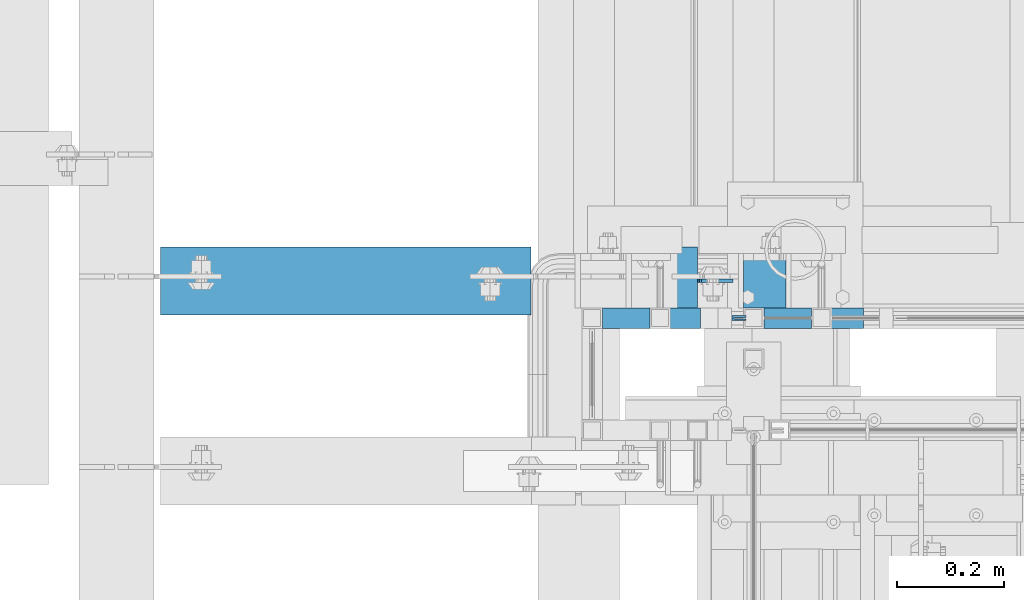
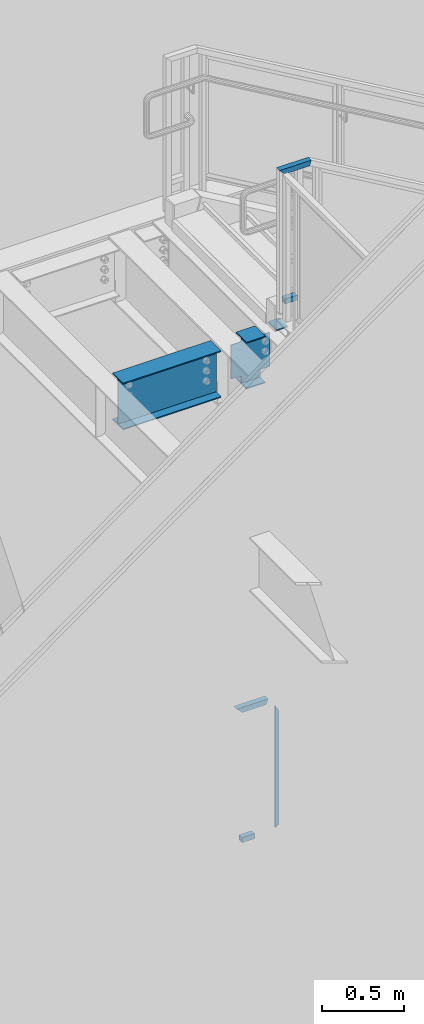
# One storey, part 929 of 1179: 4 beams, 4 members, 5 elements without a shape of their own.
"""IFC2X3 building model written with IfcOpenShell, lengths in millimetres."""

from ifc_helpers import new_model, si_unit, frame, origin_with_axes, place, context, subcontext, project, spatial, faceted_brep, material, type_object, element, aggregate, save


model = new_model("IFC2X3")

# Units and contexts
model_context = context("Model", 3, precision=1e-05, world=origin_with_axes())
body_context = subcontext(model_context, "Body", "Model", "MODEL_VIEW")
ifc_project = project(units=[si_unit("LENGTHUNIT", "METRE", prefix="MILLI"), si_unit("AREAUNIT", "SQUARE_METRE"), si_unit("VOLUMEUNIT", "CUBIC_METRE"), si_unit("MASSUNIT", "GRAM", prefix="KILO"), si_unit("TIMEUNIT", "SECOND"), si_unit("PLANEANGLEUNIT", "RADIAN"), si_unit("SOLIDANGLEUNIT", "STERADIAN"), si_unit("THERMODYNAMICTEMPERATUREUNIT", "DEGREE_CELSIUS"), si_unit("LUMINOUSINTENSITYUNIT", "LUMEN")], contexts=[model_context])

# Site, building, storey
site_placement = place(None, origin_with_axes())
site = spatial("IfcSite", under=ifc_project, at=site_placement, CompositionType="ELEMENT")
building_placement = place(site_placement, origin_with_axes())
building = spatial("IfcBuilding", under=site, at=building_placement, Name="Undefined", CompositionType="ELEMENT")
storey_placement = place(building_placement, origin_with_axes())
storey = spatial("IfcBuildingStorey", under=building, at=storey_placement, Name="Undefined", CompositionType="ELEMENT", Elevation=0.0)

# Assembly, beam
assembly_1_placement = place(storey_placement, origin_with_axes())
assembly_1 = element("IfcElementAssembly", 1, at=assembly_1_placement, inside=storey, Name="GUARDRAIL", AssemblyPlace="NOTDEFINED", PredefinedType="RIGID_FRAME")
ifc_material_1 = material(Name="STEEL/BUY-OUT")
beam_type_1 = type_object("IfcBeamType", PredefinedType="NOTDEFINED")
beam_1_placement = place(assembly_1_placement, frame((19591.0331071758, 39677.9751661867, 4786.47180551808), z_axis=(0.0, 0.0, -1.0), x_axis=(-1.0, 0.0, 0.0)))
beam_1 = element("IfcBeam", 2, at=beam_1_placement, type_object=beam_type_1, material=ifc_material_1, Name="U-EDGE", context=body_context, shape_type="Brep", body=[
    faceted_brep([(2.91038304567337e-11, 7.9375, 440.175302877862), (25.3999999999687, 7.9375, 454.819), (25.400000000016, 7.9375, -454.819), (2.91038304567337e-11, 7.9375, -410.76229705665), (2.91038304567337e-11, 4.76249999999709, 440.175302877862), (2.91038304567337e-11, 4.76249999999709, -410.76229705665), (22.2250000000131, 4.76249999999709, 452.988538277322), (22.2250000000131, 4.76249999999709, -449.311912132071), (22.2250000000131, 1.58750000000146, 452.988538277322), (22.2250000000131, 1.58750000000146, -449.311912132071), (0.0, 1.58750000000146, 440.175302877845), (0.0, 1.58750000000146, -410.7622970566), (0.0, -1.58750000000146, 440.175302877845), (0.0, -1.58750000000146, -410.7622970566), (25.3999999999687, -1.58750000000146, 454.819), (25.400000000016, -1.58750000000146, -454.819)], [[[0, 1, 2, 3]], [[4, 0, 3, 5]], [[6, 4, 5, 7]], [[8, 6, 7, 9]], [[10, 8, 9, 11]], [[12, 10, 11, 13]], [[14, 12, 13, 15]], [[11, 9, 7, 5, 3, 2, 15, 13]], [[1, 14, 15, 2]], [[0, 4, 6, 8, 10, 12, 14, 1]]]),
])

# Assembly, members
assembly_2_placement = place(storey_placement, origin_with_axes())
assembly_2 = element("IfcElementAssembly", 3, at=assembly_2_placement, inside=storey, Name="GUARDRAIL", AssemblyPlace="NOTDEFINED", PredefinedType="RIGID_FRAME")
ifc_material_2 = material()
member_type = type_object("IfcMemberType", Name="HSS1-1/2X1-1/2X1/8", PredefinedType="NOTDEFINED")
member_1_placement = place(assembly_2_placement, frame((19611.9749972912, 39681.1500007796, 8242.29999930855), z_axis=(0.0, -1.0, 0.0), x_axis=(1.0, 0.0, 0.0)))
member_1 = element("IfcMember", 4, at=member_1_placement, type_object=member_type, material=ifc_material_2, Name="BOTTOM_RAIL", ObjectType="HSS1-1/2X1-1/2X1/8", context=body_context, shape_type="Brep", body=[
    faceted_brep([(12.7000019468469, -19.0499992349996, 19.0500000000029), (12.7000017945174, 19.0499992350015, 19.0499992350015), (12.7000017945174, 19.0499992350015, -19.0499992350015), (12.7000019468469, -19.0499992349996, -19.0499992350015), (12.7000019362204, -15.874999282998, 15.874999282998), (12.7000019362204, -15.874999282998, -15.874999282998), (12.7000018092185, 15.8749992830017, -15.874999282998), (12.7000018092185, 15.8749992830017, 15.874999282998), (101.600003324515, 19.0499992350051, -19.0499992350015), (101.60000347684, -19.049999234996, -19.0499992350015), (101.60000347684, -19.049999234996, 19.0499992350015), (101.600003324515, 19.0499992350051, 19.0499992350015), (101.600003464151, -15.8749992829944, 15.874999282998), (101.600003337207, 15.8749992830053, 15.874999282998), (101.600003337207, 15.8749992830053, -15.874999282998), (101.600003464151, -15.8749992829944, -15.874999282998)], [[[0, 1, 2, 3], [4, 5, 6, 7]], [[8, 9, 3, 2]], [[9, 10, 0, 3]], [[10, 11, 1, 0]], [[11, 8, 2, 1]], [[10, 9, 8, 11], [12, 13, 14, 15]], [[13, 12, 4, 7]], [[14, 13, 7, 6]], [[15, 14, 6, 5]], [[12, 15, 5, 4]]]),
])
member_2_placement = place(assembly_2_placement, frame((19605.6249999269, 39681.1500007796, 9213.85000057691), z_axis=(0.0, 0.0, 1.0), x_axis=(1.0, 0.0, 0.0)))
member_2 = element("IfcMember", 5, at=member_2_placement, type_object=member_type, material=ifc_material_2, Name="TOP_RAIL", ObjectType="HSS1-1/2X1-1/2X1/8", context=body_context, shape_type="Brep", body=[
    faceted_brep([(15.874999282998, 15.874999282998, -15.8749992829999), (15.874999282998, -15.874999282998, -15.8749992829999), (195.733208365273, -15.874999282998, -15.8749992829999), (195.733208365273, 15.874999282998, -15.8749992829999), (-15.8749992830017, -15.874999282998, 15.8749992829999), (204.316793203543, -15.874999282998, 15.8749992829999), (-15.8749992830017, 15.874999282998, 15.8749992829999), (204.316793203543, 15.874999282998, 15.8749992829999), (19.0499999999993, 19.0499992349996, -19.0499992350015), (-19.0499992350015, 19.0499992350015, 19.0499992349996), (205.175151713163, 19.0499992350015, 19.0499992349996), (194.874849855652, 19.0499992350015, -19.0499992349996), (-19.0499992350015, -19.0499992350015, 19.0499992349996), (205.175151713163, -19.0499992350015, 19.0499992349996), (19.0499999999993, -19.0499992349996, -19.0499992350015), (194.874849855652, -19.0499992350015, -19.0499992349996)], [[[0, 1, 2, 3]], [[1, 4, 5, 2]], [[4, 6, 7, 5]], [[6, 0, 3, 7]], [[8, 9, 10, 11]], [[9, 12, 13, 10]], [[12, 14, 15, 13]], [[14, 8, 11, 15]], [[13, 15, 11, 10], [5, 7, 3, 2]], [[14, 12, 9, 8], [6, 4, 1, 0]]]),
])
aggregate(assembly_2, [member_1, member_2])

# Member
member_3_placement = place(assembly_1_placement, frame((19304.0000001842, 39681.150000778, 4330.70000016911), z_axis=(0.0, -1.0, 0.0), x_axis=(1.0, 0.0, 0.0)))
member_3 = element("IfcMember", 6, at=member_3_placement, type_object=member_type, material=ifc_material_2, Name="POST", ObjectType="HSS1-1/2X1-1/2X1/8", context=body_context, shape_type="Brep", body=[
    faceted_brep([(107.950001301364, -19.0499992349942, 19.0499992350015), (107.950001301364, -19.0499992349942, -19.0499992350015), (107.949999235003, 19.0499992349996, -19.0499992350015), (107.949999235003, 19.0499992349996, 19.0499992350015), (107.950001288671, -15.8749992829944, 15.874999282998), (107.950001161731, 15.8749992830053, 15.874999282998), (107.950001161731, 15.8749992830053, -15.874999282998), (107.950001288671, -15.8749992829944, -15.874999282998), (19.0499999999993, 19.0499992349996, -19.0499992350015), (19.0499999999993, 19.0499992349996, 19.0499992350015), (19.0499999999993, -19.0499992349996, 19.0500001223481), (19.0499999999993, -19.0499992349996, -19.0499992350015), (19.0499999999993, -15.8749992829999, 15.874999282998), (19.0499999999993, -15.8749992829999, -15.874999282998), (19.0499999999993, 15.8749992829999, -15.874999282998), (19.0499999999993, 15.8749992829999, 15.874999282998)], [[[0, 1, 2, 3], [4, 5, 6, 7]], [[3, 2, 8, 9]], [[9, 10, 0, 3]], [[10, 11, 1, 0]], [[11, 8, 2, 1]], [[10, 9, 8, 11], [12, 13, 14, 15]], [[13, 12, 4, 7]], [[14, 13, 7, 6]], [[15, 14, 6, 5]], [[12, 15, 5, 4]]]),
])

member_4_placement = place(assembly_1_placement, frame((19303.9999999845, 39681.150000778, 5302.25), z_axis=(0.0, 0.0, 1.0), x_axis=(1.0, 0.0, 0.0)))
member_4 = element("IfcMember", 7, at=member_4_placement, type_object=member_type, material=ifc_material_2, Name="TOP_RAIL", ObjectType="HSS1-1/2X1-1/2X1/8", context=body_context, shape_type="Brep", body=[
    faceted_brep([(15.874999282998, 15.874999282998, -15.8749992829999), (15.874999282998, -15.874999282998, -15.8749992829999), (192.585831865978, -15.874999282998, -15.8749992829999), (192.585831865978, 15.874999282998, -15.8749992829999), (-15.8749992830017, -15.874999282998, 15.8749992829999), (201.114170631146, -15.874999282998, 15.8749992829999), (-15.8749992830017, 15.874999282998, 15.8749992829999), (201.114170631146, 15.874999282998, 15.8749992829999), (19.0499999999993, 19.0499992349996, -19.0499992350015), (-19.0499992350015, 19.0499992350015, 19.0499992349996), (201.96700453329, 19.0499992350015, 19.0499992349996), (191.732997963838, 19.0499992350015, -19.0499992349996), (-19.0499992350015, -19.0499992350015, 19.0499992349996), (201.96700453329, -19.0499992350015, 19.0499992349996), (19.0499999999993, -19.0499992349996, -19.0499992350015), (191.732997963838, -19.0499992350015, -19.0499992349996)], [[[0, 1, 2, 3]], [[1, 4, 5, 2]], [[4, 6, 7, 5]], [[6, 0, 3, 7]], [[8, 9, 10, 11]], [[9, 12, 13, 10]], [[12, 14, 15, 13]], [[14, 8, 11, 15]], [[13, 15, 11, 10], [5, 7, 3, 2]], [[14, 12, 9, 8], [6, 4, 1, 0]]]),
])

aggregate(assembly_1, [beam_1, member_3, member_4])

# Assembly, beam
assembly_3_placement = place(storey_placement, origin_with_axes())
assembly_3 = element("IfcElementAssembly", 8, at=assembly_3_placement, inside=storey, Name="STAIR", AssemblyPlace="NOTDEFINED", PredefinedType="RIGID_FRAME")
ifc_material_3 = material(Name="STEEL/A36")
beam_type_2 = type_object("IfcBeamType", PredefinedType="NOTDEFINED")
beam_2_placement = place(assembly_3_placement, frame((19665.94999773, 39751.0000000355, 8018.46249982856), z_axis=(0.0, -1.0, 0.0), x_axis=(-1.0, 0.0, 0.0)))
beam_2 = element("IfcBeam", 9, at=beam_2_placement, type_object=beam_type_2, material=ifc_material_3, Name="PLATE", context=body_context, shape_type="Brep", body=[
    faceted_brep([(0.0, 4.76249999999982, -50.7999999999993), (0.0, 4.76249999999982, 50.7999999999993), (79.3749874406894, 4.76250000000073, 50.8000000000029), (79.3749874406894, 4.76250000000073, -50.8000000000029), (0.0, -4.76249999999982, 50.7999999999993), (79.3749874406822, -4.76249999999982, 50.8000000000029), (0.0, -4.76249999999982, -50.7999999999993), (79.3749874406822, -4.76249999999982, -50.8000000000029)], [[[0, 1, 2, 3]], [[1, 4, 5, 2]], [[4, 6, 7, 5]], [[6, 0, 3, 7]], [[5, 7, 3, 2]], [[6, 4, 1, 0]]]),
])
aggregate(assembly_3, [beam_2])

assembly_4_placement = place(storey_placement, origin_with_axes())
assembly_4 = element("IfcElementAssembly", 10, at=assembly_4_placement, inside=storey, Name="BEAM", AssemblyPlace="NOTDEFINED", PredefinedType="RIGID_FRAME")
ifc_material_4 = material(Name="STEEL/A992")
beam_type_3 = type_object("IfcBeamType", Name="W14X22", PredefinedType="NOTDEFINED")
beam_3_placement = place(assembly_4_placement, frame((19278.6, 39751.000000021, 7839.075), z_axis=(0.0, 0.0, 1.0), x_axis=(1.0, 0.0, 0.0)))
beam_3 = element("IfcBeam", 11, at=beam_3_placement, type_object=beam_type_3, material=ifc_material_4, Name="BEAM", ObjectType="W14X22", context=body_context, shape_type="Brep", body=[
    faceted_brep([(222.25, -3.17500000000291, -166.6875), (222.25, -63.5, -166.6875), (222.25, -63.5, -174.625), (222.25, 63.5, -174.625), (222.25, 63.5, -166.6875), (222.25, 3.17500000000291, -166.6875), (222.25, 3.17500000000291, -123.824999809265), (222.25, -3.17500000000291, -123.824999809265), (223.216729922588, 3.17500000000291, -118.96492029122), (223.216729922588, -3.17500000000291, -118.96492029122), (225.969743823065, 3.17500000000291, -114.844743823066), (225.969743823065, -3.17500000000291, -114.844743823066), (230.089920291219, 3.17500000000291, -112.091729922588), (230.089920291219, -3.17500000000291, -112.091729922588), (234.949999809265, 3.17500000000291, -111.125), (234.949999809265, -3.17500000000291, -111.125), (288.924999999999, -3.17500000000291, -111.125), (288.924999999999, 3.17500000000291, -111.125), (89.6937500000022, 3.17500000000291, 166.6875), (89.6937500000022, 63.5, 166.6875), (222.25, 63.5, 166.6875), (222.25, 3.17500000000291, 166.6875), (89.6937500000022, -3.17500000000291, -123.824999809265), (89.6937500000022, 3.17500000000291, -123.824999809265), (89.6937500000022, 3.17500000000291, -166.6875), (89.6937500000022, 63.5, -166.6875), (89.6937500000022, 63.5, -174.625), (89.6937500000022, -63.5, -174.625), (89.6937500000022, -63.5, -166.6875), (89.6937500000022, -3.17500000000291, -166.6875), (88.7270200774146, -3.17500000000291, -118.96492029122), (88.7270200774146, 3.17500000000291, -118.96492029122), (85.9740061769371, -3.17500000000291, -114.844743823066), (85.9740061769371, 3.17500000000291, -114.844743823066), (81.8538297087835, -3.17500000000291, -112.091729922588), (81.8538297087835, 3.17500000000291, -112.091729922588), (76.993750190737, -3.17500000000291, -111.125), (76.993750190737, 3.17500000000291, -111.125), (16.6687500000007, -3.17500000000291, -111.125), (16.6687500000007, 3.17500000000291, -111.125), (16.6687500000007, -3.17500000000291, 142.875), (16.6687500000007, 3.17500000000291, 142.875), (76.993750190737, -3.17500000000291, 142.875), (76.993750190737, 3.17500000000291, 142.875), (81.8538297087835, -3.17500000000291, 143.841729922588), (81.8538297087835, 3.17500000000291, 143.841729922588), (85.9740061769371, -3.17500000000291, 146.594743823066), (85.9740061769371, 3.17500000000291, 146.594743823066), (88.7270200774146, -3.17500000000291, 150.71492029122), (88.7270200774146, 3.17500000000291, 150.71492029122), (89.6937500000022, -3.17500000000291, 155.574999809265), (89.6937500000022, 3.17500000000291, 155.574999809265), (89.6937500000022, -63.5, 174.625), (89.6937500000022, 63.5, 174.625), (89.6937500000022, -3.17500000000291, 166.6875), (89.6937500000022, -63.5, 166.6875), (222.25, -3.17500000000291, 166.6875), (222.25, -63.5, 166.6875), (222.25, -63.5, 174.625), (222.25, 63.5, 174.625), (222.25, -3.17500000000291, 155.574999809265), (222.25, 3.17500000000291, 155.574999809265), (223.216729922588, -3.17500000000291, 150.71492029122), (223.216729922588, 3.17500000000291, 150.71492029122), (225.969743823065, -3.17500000000291, 146.594743823066), (225.969743823065, 3.17500000000291, 146.594743823066), (230.089920291219, -3.17500000000291, 143.841729922588), (230.089920291219, 3.17500000000291, 143.841729922588), (234.949999809265, -3.17500000000291, 142.875), (234.949999809265, 3.17500000000291, 142.875), (288.924999999999, -3.17500000000291, 142.875), (288.924999999999, 3.17500000000291, 142.875)], [[[0, 1, 2, 3, 4, 5, 6, 7]], [[7, 6, 8, 9]], [[9, 8, 10, 11]], [[11, 10, 12, 13]], [[13, 12, 14, 15]], [[16, 15, 14, 17]], [[18, 19, 20, 21]], [[22, 23, 24, 25, 26, 27, 28, 29]], [[30, 31, 23, 22]], [[32, 33, 31, 30]], [[34, 35, 33, 32]], [[36, 37, 35, 34]], [[38, 39, 37, 36]], [[40, 41, 39, 38]], [[42, 43, 41, 40]], [[44, 45, 43, 42]], [[46, 47, 45, 44]], [[48, 49, 47, 46]], [[50, 51, 49, 48]], [[52, 53, 19, 18, 51, 50, 54, 55]], [[55, 54, 56, 57]], [[52, 55, 57, 58]], [[53, 52, 58, 59]], [[19, 53, 59, 20]], [[58, 57, 56, 60, 61, 21, 20, 59]], [[62, 63, 61, 60]], [[64, 65, 63, 62]], [[66, 67, 65, 64]], [[68, 69, 67, 66]], [[70, 71, 69, 68]], [[71, 70, 16, 17]], [[12, 10, 8, 6, 5, 24, 23, 31, 33, 35, 37, 39, 41, 43, 45, 47, 49, 51, 18, 21, 61, 63, 65, 67, 69, 71, 17, 14]], [[25, 24, 5, 4]], [[26, 25, 4, 3]], [[27, 26, 3, 2]], [[28, 27, 2, 1]], [[29, 28, 1, 0]], [[70, 68, 66, 64, 62, 60, 56, 54, 50, 48, 46, 44, 42, 40, 38, 36, 34, 32, 30, 22, 29, 0, 7, 9, 11, 13, 15, 16]]]),
])
aggregate(assembly_4, [beam_3])

assembly_5_placement = place(storey_placement, origin_with_axes())
assembly_5 = element("IfcElementAssembly", 12, at=assembly_5_placement, inside=storey, Name="BEAM", AssemblyPlace="NOTDEFINED", PredefinedType="RIGID_FRAME")
beam_4_placement = place(assembly_5_placement, frame((18415.0, 39751.000000021, 7839.075), z_axis=(0.0, 0.0, 1.0), x_axis=(1.0, 0.0, 0.0)))
beam_4 = element("IfcBeam", 13, at=beam_4_placement, type_object=beam_type_3, material=ifc_material_4, Name="BEAM", ObjectType="W14X22", context=body_context, shape_type="Brep", body=[
    faceted_brep([(82.5499999999993, -63.5, -174.625), (82.5499999999993, 63.5, -174.625), (774.700000000001, 63.5, -174.625), (774.700000000001, -63.5, -174.625), (82.5499999999993, -63.5, -166.6875), (82.5499999999993, -3.17500000000291, -166.6875), (82.5499999999993, -3.17500000000291, 166.6875), (82.5499999999993, -63.5, 166.6875), (82.5499999999993, -63.5, 174.625), (82.5499999999993, 63.5, 174.625), (82.5499999999993, 63.5, 166.6875), (82.5499999999993, 3.17500000000291, 166.6875), (82.5499999999993, 3.17500000000291, 137.265000000114), (82.5499999999993, 3.17500000000291, -92.8149999999623), (82.5499999999993, 3.17500000000291, -166.6875), (82.5499999999993, 63.5, -166.6875), (774.700000000001, -63.5, -166.6875), (774.700000000001, -3.17500000000291, -166.6875), (774.700000000001, -3.17500000000291, 166.6875), (774.700000000001, -63.5, 166.6875), (774.700000000001, -63.5, 174.625), (774.700000000001, 63.5, 174.625), (774.700000000001, 63.5, 166.6875), (774.700000000001, 3.17500000000291, 166.6875), (774.700000000001, 3.17500000000291, 137.265000000132), (774.700000000001, 3.17500000000291, -92.8149999999441), (774.700000000001, 3.17500000000291, -166.6875), (774.700000000001, 63.5, -166.6875)], [[[0, 1, 2, 3]], [[0, 4, 5, 6, 7, 8, 9, 10, 11, 12, 13, 14, 15, 1]], [[5, 4, 16, 17]], [[6, 5, 17, 18]], [[7, 6, 18, 19]], [[8, 7, 19, 20]], [[9, 8, 20, 21]], [[10, 9, 21, 22]], [[11, 10, 22, 23]], [[14, 13, 12, 11, 23, 24, 25, 26]], [[15, 14, 26, 27]], [[1, 15, 27, 2]], [[26, 25, 24, 23, 22, 21, 20, 19, 18, 17, 16, 3, 2, 27]], [[4, 0, 3, 16]]]),
])
aggregate(assembly_5, [beam_4])

save(model, "model.ifc")
